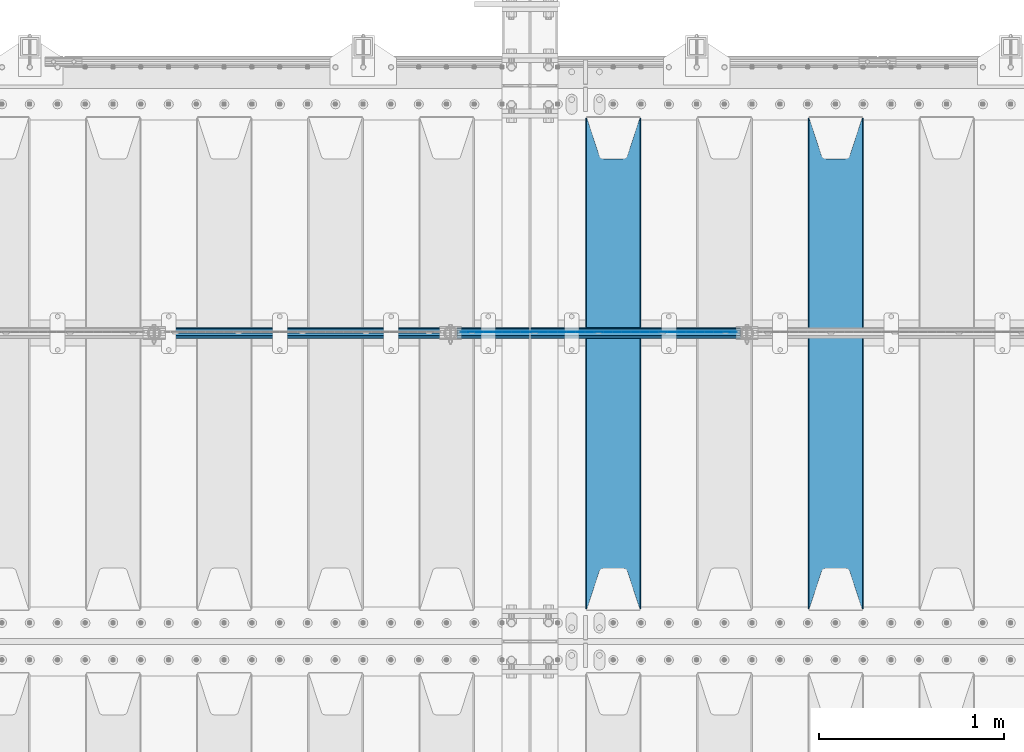
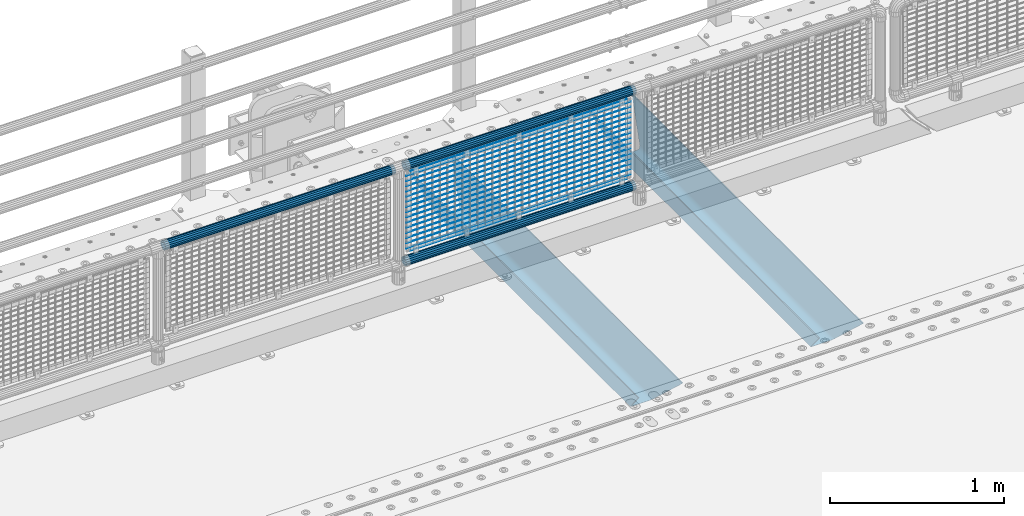
# One storey, part 106 of 208: 22 beams.
"""IFC2X3 building model written with IfcOpenShell, lengths in millimetres."""

from ifc_helpers import new_model, si_unit, frame, origin_with_axes, place, context, subcontext, project, spatial, faceted_brep, material, type_object, element, save


model = new_model("IFC2X3")

# Units and contexts
model_context = context("Model", 3, precision=1e-05, world=origin_with_axes())
body_context = subcontext(model_context, "Body", "Model", "MODEL_VIEW")
ifc_project = project(units=[si_unit("LENGTHUNIT", "METRE", prefix="MILLI"), si_unit("AREAUNIT", "SQUARE_METRE"), si_unit("VOLUMEUNIT", "CUBIC_METRE"), si_unit("MASSUNIT", "GRAM", prefix="KILO"), si_unit("TIMEUNIT", "SECOND"), si_unit("PLANEANGLEUNIT", "RADIAN"), si_unit("SOLIDANGLEUNIT", "STERADIAN"), si_unit("THERMODYNAMICTEMPERATUREUNIT", "DEGREE_CELSIUS"), si_unit("LUMINOUSINTENSITYUNIT", "LUMEN")], contexts=[model_context])

# Site, building, storey
site_placement = place(None, origin_with_axes())
site = spatial("IfcSite", under=ifc_project, at=site_placement, CompositionType="ELEMENT")
building_placement = place(site_placement, origin_with_axes())
building = spatial("IfcBuilding", under=site, at=building_placement, Name="Standard", CompositionType="ELEMENT")
storey_placement = place(building_placement, origin_with_axes())
storey = spatial("IfcBuildingStorey", under=building, at=storey_placement, Name="Undefined", CompositionType="ELEMENT", Elevation=0.0)

# Beams
ifc_material_1 = material(Name="STEEL/S355N")
beam_type_1 = type_object("IfcBeamType", PredefinedType="NOTDEFINED")
beam_1_placement = place(storey_placement, frame((-28550.0, 3175.0, -115.0), z_axis=(0.0, 0.0, 1.0), x_axis=(0.0, 1.0, 0.0)))
element("IfcBeam", 1, at=beam_1_placement, inside=storey, type_object=beam_type_1, material=ifc_material_1, context=body_context, shape_type="Brep", body=[
    faceted_brep([(0.0, 150.0, 115.0), (0.0, 143.689999999999, 115.0), (2650.00000000297, 143.689999999999, 115.0), (2650.00000000297, 150.0, 115.0), (2650.00000000297, 142.059565218402, 110.0000000031), (2650.00000000297, 148.369565218403, 110.0000000031), (2441.90079219208, -80.1103600731112, -98.0992078077845), (2437.7588105432, -77.5672621345584, -102.241189456673), (2434.06523489746, -74.4080125315522, -105.934765102404), (2430.91086095089, -70.710272125576, -109.089139048974), (2428.37322971128, -66.5649389910068, -111.626770288588), (2426.51472138055, -62.0739139532889, -113.485278619323), (2425.38102192091, -57.3475956567672, -114.618978078955), (2424.99999999987, -52.5021667386536, -115.0), (2424.99999999987, 52.5021667386536, -115.0), (2425.38102192091, 57.3475956567672, -114.618978078955), (2426.51472138055, 62.0739139532889, -113.485278619323), (2428.37322971128, 66.5649389910068, -111.626770288588), (2430.91086095089, 70.710272125576, -109.089139048974), (2434.06523489746, 74.4080125315522, -105.934765102404), (2437.7588105432, 77.5672621345584, -102.241189456673), (2441.90079219208, 80.1103600731112, -98.0992078077846), (2446.38936140511, 81.9747917625791, -93.6106385947584), (2448.24948500409, 76.2713538057251, -91.7505149957729), (2444.62967112262, 74.76777986261, -95.3703288772456), (2441.28936334126, 72.7168944282894, -98.710636658607), (2438.31067330438, 70.1691124903846, -101.689326695487), (2435.76682334747, 67.1870637758839, -104.233176652398), (2433.72034654133, 63.8440531834895, -106.279653458539), (2432.22154950041, 60.222258798236, -107.778450499454), (2431.30727574265, 56.4107117849089, -108.692724257221), (2430.99999999987, 52.5031078186876, -109.0), (2430.99999999987, -52.5031078186876, -109.0), (2431.30727574265, -56.4107117849089, -108.692724257221), (2432.22154950041, -60.222258798236, -107.778450499454), (2433.72034654133, -63.8440531834895, -106.279653458539), (2435.76682334747, -67.1870637758839, -104.233176652398), (2438.31067330438, -70.1691124903846, -101.689326695487), (2441.28936334126, -72.7168944282894, -98.7106366586071), (2444.62967112262, -74.76777986261, -95.3703288772457), (2448.24948500409, -76.2713538057251, -91.7505149957729), (2650.00000000297, -142.059565218402, 110.0000000031), (2650.00000000297, -148.369565218403, 110.0000000031), (2446.38936140511, -81.9747917625791, -93.6106385947584), (2650.00000000297, -143.689999999999, 115.0), (2650.00000000297, -150.0, 115.0), (0.0, -143.689999999999, 115.0), (0.0, -150.0, 115.0), (0.0, -148.369565218261, 110.000000002663), (203.610638597421, -81.9747917625791, -93.6106385947584), (208.099207810448, -80.1103600731112, -98.0992078077845), (212.241189459336, -77.5672621345584, -102.241189456673), (215.934765105067, -74.4080125315522, -105.934765102404), (219.089139051637, -70.710272125576, -109.089139048974), (221.626770291251, -66.5649389910068, -111.626770288588), (223.485278621986, -62.0739139532889, -113.485278619323), (224.618978081618, -57.3475956567672, -114.618978078955), (225.000000002663, -52.5021667386536, -115.0), (225.000000002663, 52.5021667386536, -115.0), (224.618978081618, 57.3475956567672, -114.618978078955), (223.485278621986, 62.0739139532889, -113.485278619323), (221.626770291251, 66.5649389910068, -111.626770288588), (219.089139051637, 70.710272125576, -109.089139048974), (215.934765105067, 74.4080125315522, -105.934765102404), (212.241189459336, 77.5672621345584, -102.241189456673), (208.099207810448, 80.1103600731112, -98.0992078077846), (203.610638597421, 81.9747917625791, -93.6106385947584), (0.0, 148.369565218261, 110.000000002663), (0.0, 142.05956521826, 110.000000002663), (201.750514998436, 76.2713538057251, -91.7505149957729), (205.370328879908, 74.76777986261, -95.3703288772456), (208.71063666127, 72.7168944282894, -98.710636658607), (211.68932669815, 70.1691124903846, -101.689326695487), (214.233176655061, 67.1870637758839, -104.233176652398), (216.279653461202, 63.8440531834895, -106.279653458539), (217.778450502116, 60.222258798236, -107.778450499454), (218.692724259884, 56.4107117849089, -108.692724257221), (219.000000002663, 52.5031078186876, -109.0), (219.000000002663, -52.5031078186876, -109.0), (218.692724259884, -56.4107117849089, -108.692724257221), (217.778450502116, -60.222258798236, -107.778450499454), (216.279653461202, -63.8440531834895, -106.279653458539), (214.233176655061, -67.1870637758839, -104.233176652398), (211.68932669815, -70.1691124903846, -101.689326695487), (208.71063666127, -72.7168944282894, -98.7106366586071), (205.370328879908, -74.76777986261, -95.3703288772457), (201.750514998436, -76.2713538057251, -91.7505149957729), (0.0, -142.05956521826, 110.000000002663)], [[[0, 1, 2, 3]], [[3, 2, 4, 5]], [[6, 7, 8, 9, 10, 11, 12, 13, 14, 15, 16, 17, 18, 19, 20, 21, 22, 5, 4, 23, 24, 25, 26, 27, 28, 29, 30, 31, 32, 33, 34, 35, 36, 37, 38, 39, 40, 41, 42, 43]], [[44, 45, 42, 41]], [[46, 47, 45, 44]], [[43, 42, 45, 47, 48, 49]], [[6, 43, 49, 50]], [[7, 6, 50, 51]], [[8, 7, 51, 52]], [[9, 8, 52, 53]], [[10, 9, 53, 54]], [[11, 10, 54, 55]], [[12, 11, 55, 56]], [[13, 12, 56, 57]], [[14, 13, 57, 58]], [[15, 14, 58, 59]], [[16, 15, 59, 60]], [[17, 16, 60, 61]], [[18, 17, 61, 62]], [[19, 18, 62, 63]], [[20, 19, 63, 64]], [[21, 20, 64, 65]], [[22, 21, 65, 66]], [[0, 3, 5, 22, 66, 67]], [[1, 0, 67, 68]], [[23, 4, 2, 1, 68, 69]], [[24, 23, 69, 70]], [[25, 24, 70, 71]], [[26, 25, 71, 72]], [[27, 26, 72, 73]], [[28, 27, 73, 74]], [[29, 28, 74, 75]], [[30, 29, 75, 76]], [[31, 30, 76, 77]], [[32, 31, 77, 78]], [[33, 32, 78, 79]], [[34, 33, 79, 80]], [[35, 34, 80, 81]], [[36, 35, 81, 82]], [[37, 36, 82, 83]], [[38, 37, 83, 84]], [[39, 38, 84, 85]], [[40, 39, 85, 86]], [[46, 44, 41, 40, 86, 87]], [[47, 46, 87, 48]], [[86, 85, 84, 83, 82, 81, 80, 79, 78, 77, 76, 75, 74, 73, 72, 71, 70, 69, 68, 67, 66, 65, 64, 63, 62, 61, 60, 59, 58, 57, 56, 55, 54, 53, 52, 51, 50, 49, 48, 87]]]),
])
beam_2_placement = place(storey_placement, frame((-29750.0, 3175.0, -115.0), z_axis=(0.0, 0.0, 1.0), x_axis=(0.0, 1.0, 0.0)))
element("IfcBeam", 2, at=beam_2_placement, inside=storey, type_object=beam_type_1, material=ifc_material_1, context=body_context, shape_type="Brep", body=[
    faceted_brep([(0.0, 150.0, 115.0), (0.0, 143.689999999999, 115.0), (2650.00000000297, 143.689999999999, 115.0), (2650.00000000297, 150.0, 115.0), (2650.00000000297, 142.059565218402, 110.0000000031), (2650.00000000297, 148.369565218403, 110.0000000031), (2441.90079219208, -80.1103600731112, -98.0992078077845), (2437.7588105432, -77.5672621345584, -102.241189456673), (2434.06523489746, -74.4080125315522, -105.934765102404), (2430.91086095089, -70.710272125576, -109.089139048974), (2428.37322971128, -66.5649389910068, -111.626770288588), (2426.51472138055, -62.0739139532889, -113.485278619323), (2425.38102192091, -57.3475956567672, -114.618978078955), (2424.99999999987, -52.5021667386536, -115.0), (2424.99999999987, 52.5021667386536, -115.0), (2425.38102192091, 57.3475956567672, -114.618978078955), (2426.51472138055, 62.0739139532889, -113.485278619323), (2428.37322971128, 66.5649389910068, -111.626770288588), (2430.91086095089, 70.710272125576, -109.089139048974), (2434.06523489746, 74.4080125315522, -105.934765102404), (2437.7588105432, 77.5672621345584, -102.241189456673), (2441.90079219208, 80.1103600731112, -98.0992078077846), (2446.38936140511, 81.9747917625791, -93.6106385947584), (2448.24948500409, 76.2713538057251, -91.7505149957729), (2444.62967112262, 74.76777986261, -95.3703288772456), (2441.28936334126, 72.7168944282894, -98.710636658607), (2438.31067330438, 70.1691124903846, -101.689326695487), (2435.76682334747, 67.1870637758839, -104.233176652398), (2433.72034654133, 63.8440531834895, -106.279653458539), (2432.22154950041, 60.222258798236, -107.778450499454), (2431.30727574265, 56.4107117849089, -108.692724257221), (2430.99999999987, 52.5031078186876, -109.0), (2430.99999999987, -52.5031078186876, -109.0), (2431.30727574265, -56.4107117849089, -108.692724257221), (2432.22154950041, -60.222258798236, -107.778450499454), (2433.72034654133, -63.8440531834895, -106.279653458539), (2435.76682334747, -67.1870637758839, -104.233176652398), (2438.31067330438, -70.1691124903846, -101.689326695487), (2441.28936334126, -72.7168944282894, -98.7106366586071), (2444.62967112262, -74.76777986261, -95.3703288772457), (2448.24948500409, -76.2713538057251, -91.7505149957729), (2650.00000000297, -142.059565218402, 110.0000000031), (2650.00000000297, -148.369565218403, 110.0000000031), (2446.38936140511, -81.9747917625791, -93.6106385947584), (2650.00000000297, -143.689999999999, 115.0), (2650.00000000297, -150.0, 115.0), (0.0, -143.689999999999, 115.0), (0.0, -150.0, 115.0), (0.0, -148.369565218261, 110.000000002663), (203.610638597421, -81.9747917625791, -93.6106385947584), (208.099207810448, -80.1103600731112, -98.0992078077845), (212.241189459336, -77.5672621345584, -102.241189456673), (215.934765105067, -74.4080125315522, -105.934765102404), (219.089139051637, -70.710272125576, -109.089139048974), (221.626770291251, -66.5649389910068, -111.626770288588), (223.485278621986, -62.0739139532889, -113.485278619323), (224.618978081618, -57.3475956567672, -114.618978078955), (225.000000002663, -52.5021667386536, -115.0), (225.000000002663, 52.5021667386536, -115.0), (224.618978081618, 57.3475956567672, -114.618978078955), (223.485278621986, 62.0739139532889, -113.485278619323), (221.626770291251, 66.5649389910068, -111.626770288588), (219.089139051637, 70.710272125576, -109.089139048974), (215.934765105067, 74.4080125315522, -105.934765102404), (212.241189459336, 77.5672621345584, -102.241189456673), (208.099207810448, 80.1103600731112, -98.0992078077846), (203.610638597421, 81.9747917625791, -93.6106385947584), (0.0, 148.369565218261, 110.000000002663), (0.0, 142.05956521826, 110.000000002663), (201.750514998436, 76.2713538057251, -91.7505149957729), (205.370328879908, 74.76777986261, -95.3703288772456), (208.71063666127, 72.7168944282894, -98.710636658607), (211.68932669815, 70.1691124903846, -101.689326695487), (214.233176655061, 67.1870637758839, -104.233176652398), (216.279653461202, 63.8440531834895, -106.279653458539), (217.778450502116, 60.222258798236, -107.778450499454), (218.692724259884, 56.4107117849089, -108.692724257221), (219.000000002663, 52.5031078186876, -109.0), (219.000000002663, -52.5031078186876, -109.0), (218.692724259884, -56.4107117849089, -108.692724257221), (217.778450502116, -60.222258798236, -107.778450499454), (216.279653461202, -63.8440531834895, -106.279653458539), (214.233176655061, -67.1870637758839, -104.233176652398), (211.68932669815, -70.1691124903846, -101.689326695487), (208.71063666127, -72.7168944282894, -98.7106366586071), (205.370328879908, -74.76777986261, -95.3703288772457), (201.750514998436, -76.2713538057251, -91.7505149957729), (0.0, -142.05956521826, 110.000000002663)], [[[0, 1, 2, 3]], [[3, 2, 4, 5]], [[6, 7, 8, 9, 10, 11, 12, 13, 14, 15, 16, 17, 18, 19, 20, 21, 22, 5, 4, 23, 24, 25, 26, 27, 28, 29, 30, 31, 32, 33, 34, 35, 36, 37, 38, 39, 40, 41, 42, 43]], [[44, 45, 42, 41]], [[46, 47, 45, 44]], [[43, 42, 45, 47, 48, 49]], [[6, 43, 49, 50]], [[7, 6, 50, 51]], [[8, 7, 51, 52]], [[9, 8, 52, 53]], [[10, 9, 53, 54]], [[11, 10, 54, 55]], [[12, 11, 55, 56]], [[13, 12, 56, 57]], [[14, 13, 57, 58]], [[15, 14, 58, 59]], [[16, 15, 59, 60]], [[17, 16, 60, 61]], [[18, 17, 61, 62]], [[19, 18, 62, 63]], [[20, 19, 63, 64]], [[21, 20, 64, 65]], [[22, 21, 65, 66]], [[0, 3, 5, 22, 66, 67]], [[1, 0, 67, 68]], [[23, 4, 2, 1, 68, 69]], [[24, 23, 69, 70]], [[25, 24, 70, 71]], [[26, 25, 71, 72]], [[27, 26, 72, 73]], [[28, 27, 73, 74]], [[29, 28, 74, 75]], [[30, 29, 75, 76]], [[31, 30, 76, 77]], [[32, 31, 77, 78]], [[33, 32, 78, 79]], [[34, 33, 79, 80]], [[35, 34, 80, 81]], [[36, 35, 81, 82]], [[37, 36, 82, 83]], [[38, 37, 83, 84]], [[39, 38, 84, 85]], [[40, 39, 85, 86]], [[46, 44, 41, 40, 86, 87]], [[47, 46, 87, 48]], [[86, 85, 84, 83, 82, 81, 80, 79, 78, 77, 76, 75, 74, 73, 72, 71, 70, 69, 68, 67, 66, 65, 64, 63, 62, 61, 60, 59, 58, 57, 56, 55, 54, 53, 52, 51, 50, 49, 48, 87]]]),
])
ifc_material_2 = material(Name="Misc_Undefined")
beam_type_2 = type_object("IfcBeamType", Name="D3", PredefinedType="NOTDEFINED")
for number, where, z_axis, x_axis in (
    (3, (-30574.0, 4670.50000000001, 851.597000000005), (0.0, 0.0, 1.0), (1.0, 0.0, 0.0)),
    (4, (-30574.0, 4670.50000000001, 669.452000000005), (0.0, 0.0, 1.0), (1.0, 0.0, 0.0)),
    (5, (-30574.0, 4670.50000000001, 523.736000000005), (0.0, 0.0, 1.0), (1.0, 0.0, 0.0)),
    (6, (-30574.0, 4670.50000000001, 487.307000000005), (0.0, 0.0, 1.0), (1.0, 0.0, 0.0)),
    (7, (-30574.0, 4670.50000000001, 705.881000000005), (0.0, 0.0, 1.0), (1.0, 0.0, 0.0)),
    (8, (-30574.0, 4670.50000000001, 596.594000000005), (0.0, 0.0, 1.0), (1.0, 0.0, 0.0)),
    (9, (-30574.0, 4670.50000000001, 450.878000000005), (0.0, 0.0, 1.0), (1.0, 0.0, 0.0)),
    (10, (-30574.0, 4670.50000000001, 815.168000000005), (0.0, 0.0, 1.0), (1.0, 0.0, 0.0)),
    (11, (-30574.0, 4670.50000000001, 888.026000000005), (0.0, 0.0, 1.0), (1.0, 0.0, 0.0)),
    (12, (-30574.0, 4670.50000000001, 778.739000000005), (0.0, 0.0, 1.0), (1.0, 0.0, 0.0)),
    (13, (-30574.0, 4670.50000000001, 742.310000000005), (0.0, 0.0, 1.0), (1.0, 0.0, 0.0)),
    (14, (-30574.0, 4670.50000000001, 633.023000000005), (0.0, 0.0, 1.0), (1.0, 0.0, 0.0)),
    (15, (-30574.0, 4670.50000000001, 560.165000000005), (0.0, 0.0, 1.0), (1.0, 0.0, 0.0)),
    (16, (-30574.0, 4670.50000000001, 414.449000000005), (0.0, 0.0, 1.0), (1.0, 0.0, 0.0)),
):
    element("IfcBeam", number, at=place(storey_placement, frame(where, z_axis=z_axis, x_axis=x_axis)), inside=storey, type_object=beam_type_2, material=ifc_material_2, ObjectType="D3", context=body_context, shape_type="Brep", body=[
        faceted_brep([(0.0, -1.49999999999909, 3.63797880709171e-12), (-7.27595761418343e-12, -0.749999999999091, -1.29903810567669), (1490.0, -0.75, -1.29903810567669), (1490.0, -1.5, 0.0), (-3.63797880709171e-12, 0.750000000000909, -1.29903810567669), (1490.0, 0.75, -1.29903810567669), (0.0, 1.50000000000182, 3.63797880709171e-12), (1490.0, 1.5, 0.0), (-3.63797880709171e-12, 0.750000000000909, 1.29903810567669), (1490.0, 0.75, 1.29903810567669), (-7.27595761418343e-12, -0.749999999999091, 1.29903810567669), (1490.0, -0.75, 1.29903810567669)], [[[0, 1, 2, 3]], [[1, 4, 5, 2]], [[4, 6, 7, 5]], [[6, 8, 9, 7]], [[8, 10, 11, 9]], [[10, 0, 3, 11]], [[5, 7, 9, 11, 3, 2]], [[10, 8, 6, 4, 1, 0]]]),
    ])
beam_3_placement = place(storey_placement, frame((-30549.0, 4670.50000000001, 353.020000000005), z_axis=(0.0, 0.0, 1.0), x_axis=(1.0, 0.0, 0.0)))
element("IfcBeam", 17, at=beam_3_placement, inside=storey, type_object=beam_type_2, material=ifc_material_2, ObjectType="D3", context=body_context, shape_type="Brep", body=[
    faceted_brep([(0.0, -1.49999999999909, 3.63797880709171e-12), (-7.27595761418343e-12, -0.749999999999091, -1.29903810567669), (1440.0, -0.75, -1.29903810567669), (1440.0, -1.5, 0.0), (-3.63797880709171e-12, 0.750000000000909, -1.29903810567669), (1440.0, 0.75, -1.29903810567663), (0.0, 1.50000000000182, 3.63797880709171e-12), (1440.0, 1.5, 0.0), (-3.63797880709171e-12, 0.750000000000909, 1.29903810567669), (1440.0, 0.75, 1.29903810567669), (-7.27595761418343e-12, -0.749999999999091, 1.29903810567669), (1440.0, -0.75, 1.29903810567669)], [[[0, 1, 2, 3]], [[1, 4, 5, 2]], [[4, 6, 7, 5]], [[6, 8, 9, 7]], [[8, 10, 11, 9]], [[10, 0, 3, 11]], [[5, 7, 9, 11, 3, 2]], [[10, 8, 6, 4, 1, 0]]]),
])
beam_4_placement = place(storey_placement, frame((-30574.0, 4670.50000000001, 378.020000000005), z_axis=(0.0, 0.0, 1.0), x_axis=(1.0, 0.0, 0.0)))
element("IfcBeam", 18, at=beam_4_placement, inside=storey, type_object=beam_type_2, material=ifc_material_2, ObjectType="D3", context=body_context, shape_type="Brep", body=[
    faceted_brep([(0.0, -1.49999999999909, 3.63797880709171e-12), (-7.27595761418343e-12, -0.749999999999091, -1.29903810567669), (1490.0, -0.75, -1.29903810567669), (1490.0, -1.5, 0.0), (-3.63797880709171e-12, 0.750000000000909, -1.29903810567669), (1490.0, 0.75, -1.29903810567669), (0.0, 1.50000000000182, 3.63797880709171e-12), (1490.0, 1.5, 0.0), (-3.63797880709171e-12, 0.750000000000909, 1.29903810567669), (1490.0, 0.75, 1.29903810567669), (-7.27595761418343e-12, -0.749999999999091, 1.29903810567669), (1490.0, -0.75, 1.29903810567669)], [[[0, 1, 2, 3]], [[1, 4, 5, 2]], [[4, 6, 7, 5]], [[6, 8, 9, 7]], [[8, 10, 11, 9]], [[10, 0, 3, 11]], [[5, 7, 9, 11, 3, 2]], [[10, 8, 6, 4, 1, 0]]]),
])
beam_5_placement = place(storey_placement, frame((-30549.0, 4670.50000000001, 913.020000000005), z_axis=(0.0, 0.0, 1.0), x_axis=(1.0, 0.0, 0.0)))
element("IfcBeam", 19, at=beam_5_placement, inside=storey, type_object=beam_type_2, material=ifc_material_2, ObjectType="D3", context=body_context, shape_type="Brep", body=[
    faceted_brep([(0.0, -1.49999999999909, 3.63797880709171e-12), (-7.27595761418343e-12, -0.749999999999091, -1.29903810567669), (1440.0, -0.75, -1.29903810567669), (1440.0, -1.5, 0.0), (-3.63797880709171e-12, 0.750000000000909, -1.29903810567669), (1440.0, 0.75, -1.29903810567663), (0.0, 1.50000000000182, 3.63797880709171e-12), (1440.0, 1.5, 0.0), (-3.63797880709171e-12, 0.750000000000909, 1.29903810567669), (1440.0, 0.75, 1.29903810567669), (-7.27595761418343e-12, -0.749999999999091, 1.29903810567669), (1440.0, -0.75, 1.29903810567669)], [[[0, 1, 2, 3]], [[1, 4, 5, 2]], [[4, 6, 7, 5]], [[6, 8, 9, 7]], [[8, 10, 11, 9]], [[10, 0, 3, 11]], [[5, 7, 9, 11, 3, 2]], [[10, 8, 6, 4, 1, 0]]]),
])
ifc_material_3 = material()
beam_type_3 = type_object("IfcBeamType", PredefinedType="NOTDEFINED")
beam_6_placement = place(storey_placement, frame((-30594.15, 4664.50000000001, 298.170000000006), z_axis=(0.0, 0.0, 1.0), x_axis=(1.0, 0.0, 0.0)))
element("IfcBeam", 20, at=beam_6_placement, inside=storey, type_object=beam_type_3, material=ifc_material_3, context=body_context, shape_type="Brep", body=[
    faceted_brep([(0.0, -25.3500000000004, 0.0), (0.0, -23.4203461491616, 9.70102501045403), (1530.0, -23.4203461491616, 9.70102501045506), (1530.0, -25.3500000000004, 0.0), (0.0, -17.9251569030794, 17.9251569030785), (1530.0, -17.9251569030794, 17.925156903079), (0.0, -9.70102501045494, 23.4203461491597), (1530.0, -9.70102501045494, 23.4203461491611), (0.0, 0.0, 25.3499999999985), (1530.0, 0.0, 25.35), (0.0, 9.70102501045494, 23.4203461491597), (1530.0, 9.70102501045494, 23.4203461491611), (0.0, 17.9251569030794, 17.9251569030785), (1530.0, 17.9251569030794, 17.925156903079), (0.0, 23.4203461491616, 9.70102501045403), (1530.0, 23.4203461491616, 9.701025010455), (0.0, 25.3500000000004, 0.0), (1530.0, 25.3500000000004, 0.0), (0.0, 23.4203461491616, -9.70102501045403), (1530.0, 23.4203461491616, -9.70102501045506), (0.0, 17.9251569030794, -17.9251569030785), (1530.0, 17.9251569030794, -17.925156903079), (0.0, 9.70102501045494, -23.4203461491597), (1530.0, 9.70102501045494, -23.4203461491611), (0.0, 0.0, -25.3499999999985), (1530.0, 0.0, -25.35), (0.0, -9.70102501045494, -23.4203461491597), (1530.0, -9.70102501045494, -23.4203461491611), (0.0, -17.9251569030794, -17.9251569030785), (1530.0, -17.9251569030794, -17.925156903079), (0.0, -23.4203461491616, -9.70102501045403), (1530.0, -23.4203461491616, -9.701025010455), (0.0, -30.1499999999996, 0.0), (0.0, -27.8549679052148, -11.5379054858058), (1530.0, -27.8549679052148, -11.5379054858075), (1530.0, -30.1499999999996, 0.0), (0.0, -21.3192694527743, -21.3192694527752), (1530.0, -21.3192694527743, -21.3192694527744), (0.0, -11.5379054858076, -27.8549679052157), (1530.0, -11.5379054858076, -27.8549679052153), (0.0, 0.0, -30.1500000000015), (1530.0, 0.0, -30.15), (0.0, 11.5379054858076, -27.8549679052157), (1530.0, 11.5379054858076, -27.8549679052153), (0.0, 21.3192694527743, -21.3192694527752), (1530.0, 21.3192694527743, -21.3192694527744), (0.0, 27.8549679052157, -11.5379054858058), (1530.0, 27.8549679052157, -11.5379054858075), (0.0, 30.1499999999996, 0.0), (1530.0, 30.1499999999996, 0.0), (0.0, 27.8549679052157, 11.5379054858058), (1530.0, 27.8549679052157, 11.5379054858075), (0.0, 21.3192694527743, 21.3192694527752), (1530.0, 21.3192694527743, 21.3192694527744), (0.0, 11.5379054858076, 27.8549679052157), (1530.0, 11.5379054858076, 27.8549679052153), (0.0, 0.0, 30.1500000000015), (1530.0, 0.0, 30.15), (0.0, -11.5379054858076, 27.8549679052157), (1530.0, -11.5379054858076, 27.8549679052153), (0.0, -21.3192694527743, 21.3192694527752), (1530.0, -21.3192694527743, 21.3192694527744), (0.0, -27.8549679052157, 11.5379054858058), (1530.0, -27.8549679052157, 11.5379054858075)], [[[0, 1, 2, 3]], [[1, 4, 5, 2]], [[4, 6, 7, 5]], [[6, 8, 9, 7]], [[8, 10, 11, 9]], [[10, 12, 13, 11]], [[12, 14, 15, 13]], [[14, 16, 17, 15]], [[16, 18, 19, 17]], [[18, 20, 21, 19]], [[20, 22, 23, 21]], [[22, 24, 25, 23]], [[24, 26, 27, 25]], [[26, 28, 29, 27]], [[28, 30, 31, 29]], [[30, 0, 3, 31]], [[32, 33, 34, 35]], [[33, 36, 37, 34]], [[36, 38, 39, 37]], [[38, 40, 41, 39]], [[40, 42, 43, 41]], [[42, 44, 45, 43]], [[44, 46, 47, 45]], [[46, 48, 49, 47]], [[48, 50, 51, 49]], [[50, 52, 53, 51]], [[52, 54, 55, 53]], [[54, 56, 57, 55]], [[56, 58, 59, 57]], [[58, 60, 61, 59]], [[60, 62, 63, 61]], [[62, 32, 35, 63]], [[37, 39, 41, 43, 45, 47, 49, 51, 53, 55, 57, 59, 61, 63, 35, 34], [5, 7, 9, 11, 13, 15, 17, 19, 21, 23, 25, 27, 29, 31, 3, 2]], [[62, 60, 58, 56, 54, 52, 50, 48, 46, 44, 42, 40, 38, 36, 33, 32], [30, 28, 26, 24, 22, 20, 18, 16, 14, 12, 10, 8, 6, 4, 1, 0]]]),
])
beam_7_placement = place(storey_placement, frame((-30594.15, 4664.50000000001, 969.850000000005), z_axis=(0.0, 0.0, 1.0), x_axis=(1.0, 0.0, 0.0)))
element("IfcBeam", 21, at=beam_7_placement, inside=storey, type_object=beam_type_3, material=ifc_material_3, context=body_context, shape_type="Brep", body=[
    faceted_brep([(0.0, -25.3500000000004, 0.0), (0.0, -23.4203461491616, 9.70102501045403), (1530.0, -23.4203461491616, 9.70102501045506), (1530.0, -25.3500000000004, 0.0), (0.0, -17.9251569030794, 17.9251569030785), (1530.0, -17.9251569030794, 17.925156903079), (0.0, -9.70102501045494, 23.4203461491597), (1530.0, -9.70102501045494, 23.4203461491611), (0.0, 0.0, 25.3499999999985), (1530.0, 0.0, 25.35), (0.0, 9.70102501045494, 23.4203461491597), (1530.0, 9.70102501045494, 23.4203461491611), (0.0, 17.9251569030794, 17.9251569030785), (1530.0, 17.9251569030794, 17.925156903079), (0.0, 23.4203461491616, 9.70102501045403), (1530.0, 23.4203461491616, 9.701025010455), (0.0, 25.3500000000004, 0.0), (1530.0, 25.3500000000004, 0.0), (0.0, 23.4203461491616, -9.70102501045403), (1530.0, 23.4203461491616, -9.70102501045506), (0.0, 17.9251569030794, -17.9251569030785), (1530.0, 17.9251569030794, -17.925156903079), (0.0, 9.70102501045494, -23.4203461491597), (1530.0, 9.70102501045494, -23.4203461491611), (0.0, 0.0, -25.3499999999985), (1530.0, 0.0, -25.35), (0.0, -9.70102501045494, -23.4203461491597), (1530.0, -9.70102501045494, -23.4203461491611), (0.0, -17.9251569030794, -17.9251569030785), (1530.0, -17.9251569030794, -17.925156903079), (0.0, -23.4203461491616, -9.70102501045403), (1530.0, -23.4203461491616, -9.701025010455), (0.0, -30.1499999999996, 0.0), (0.0, -27.8549679052148, -11.5379054858058), (1530.0, -27.8549679052148, -11.5379054858075), (1530.0, -30.1499999999996, 0.0), (0.0, -21.3192694527743, -21.3192694527752), (1530.0, -21.3192694527743, -21.3192694527744), (0.0, -11.5379054858076, -27.8549679052157), (1530.0, -11.5379054858076, -27.8549679052153), (0.0, 0.0, -30.1500000000015), (1530.0, 0.0, -30.15), (0.0, 11.5379054858076, -27.8549679052157), (1530.0, 11.5379054858076, -27.8549679052153), (0.0, 21.3192694527743, -21.3192694527752), (1530.0, 21.3192694527743, -21.3192694527744), (0.0, 27.8549679052157, -11.5379054858058), (1530.0, 27.8549679052157, -11.5379054858075), (0.0, 30.1499999999996, 0.0), (1530.0, 30.1499999999996, 0.0), (0.0, 27.8549679052157, 11.5379054858058), (1530.0, 27.8549679052157, 11.5379054858075), (0.0, 21.3192694527743, 21.3192694527752), (1530.0, 21.3192694527743, 21.3192694527744), (0.0, 11.5379054858076, 27.8549679052157), (1530.0, 11.5379054858076, 27.8549679052153), (0.0, 0.0, 30.1500000000015), (1530.0, 0.0, 30.15), (0.0, -11.5379054858076, 27.8549679052157), (1530.0, -11.5379054858076, 27.8549679052153), (0.0, -21.3192694527743, 21.3192694527752), (1530.0, -21.3192694527743, 21.3192694527744), (0.0, -27.8549679052157, 11.5379054858058), (1530.0, -27.8549679052157, 11.5379054858075)], [[[0, 1, 2, 3]], [[1, 4, 5, 2]], [[4, 6, 7, 5]], [[6, 8, 9, 7]], [[8, 10, 11, 9]], [[10, 12, 13, 11]], [[12, 14, 15, 13]], [[14, 16, 17, 15]], [[16, 18, 19, 17]], [[18, 20, 21, 19]], [[20, 22, 23, 21]], [[22, 24, 25, 23]], [[24, 26, 27, 25]], [[26, 28, 29, 27]], [[28, 30, 31, 29]], [[30, 0, 3, 31]], [[32, 33, 34, 35]], [[33, 36, 37, 34]], [[36, 38, 39, 37]], [[38, 40, 41, 39]], [[40, 42, 43, 41]], [[42, 44, 45, 43]], [[44, 46, 47, 45]], [[46, 48, 49, 47]], [[48, 50, 51, 49]], [[50, 52, 53, 51]], [[52, 54, 55, 53]], [[54, 56, 57, 55]], [[56, 58, 59, 57]], [[58, 60, 61, 59]], [[60, 62, 63, 61]], [[62, 32, 35, 63]], [[37, 39, 41, 43, 45, 47, 49, 51, 53, 55, 57, 59, 61, 63, 35, 34], [5, 7, 9, 11, 13, 15, 17, 19, 21, 23, 25, 27, 29, 31, 3, 2]], [[62, 60, 58, 56, 54, 52, 50, 48, 46, 44, 42, 40, 38, 36, 33, 32], [30, 28, 26, 24, 22, 20, 18, 16, 14, 12, 10, 8, 6, 4, 1, 0]]]),
])
beam_8_placement = place(storey_placement, frame((-32194.15, 4664.5, 969.850000000004), z_axis=(0.0, 0.0, 1.0), x_axis=(1.0, 0.0, 0.0)))
element("IfcBeam", 22, at=beam_8_placement, inside=storey, type_object=beam_type_3, material=ifc_material_3, context=body_context, shape_type="Brep", body=[
    faceted_brep([(0.0, -25.3500000000004, 0.0), (0.0, -23.4203461491616, 9.70102501045403), (1530.0, -23.4203461491616, 9.70102501045506), (1530.0, -25.3500000000004, 0.0), (0.0, -17.9251569030794, 17.9251569030785), (1530.0, -17.9251569030794, 17.925156903079), (0.0, -9.70102501045494, 23.4203461491597), (1530.0, -9.70102501045494, 23.4203461491611), (0.0, 0.0, 25.3499999999985), (1530.0, 0.0, 25.35), (0.0, 9.70102501045494, 23.4203461491597), (1530.0, 9.70102501045494, 23.4203461491611), (0.0, 17.9251569030794, 17.9251569030785), (1530.0, 17.9251569030794, 17.925156903079), (0.0, 23.4203461491616, 9.70102501045403), (1530.0, 23.4203461491616, 9.701025010455), (0.0, 25.3500000000004, 0.0), (1530.0, 25.3500000000004, 0.0), (0.0, 23.4203461491616, -9.70102501045403), (1530.0, 23.4203461491616, -9.70102501045506), (0.0, 17.9251569030794, -17.9251569030785), (1530.0, 17.9251569030794, -17.925156903079), (0.0, 9.70102501045494, -23.4203461491597), (1530.0, 9.70102501045494, -23.4203461491611), (0.0, 0.0, -25.3499999999985), (1530.0, 0.0, -25.35), (0.0, -9.70102501045494, -23.4203461491597), (1530.0, -9.70102501045494, -23.4203461491611), (0.0, -17.9251569030794, -17.9251569030785), (1530.0, -17.9251569030794, -17.925156903079), (0.0, -23.4203461491616, -9.70102501045403), (1530.0, -23.4203461491616, -9.701025010455), (0.0, -30.1499999999996, 0.0), (0.0, -27.8549679052148, -11.5379054858058), (1530.0, -27.8549679052148, -11.5379054858075), (1530.0, -30.1499999999996, 0.0), (0.0, -21.3192694527743, -21.3192694527752), (1530.0, -21.3192694527743, -21.3192694527744), (0.0, -11.5379054858076, -27.8549679052157), (1530.0, -11.5379054858076, -27.8549679052153), (0.0, 0.0, -30.1500000000015), (1530.0, 0.0, -30.15), (0.0, 11.5379054858076, -27.8549679052157), (1530.0, 11.5379054858076, -27.8549679052153), (0.0, 21.3192694527743, -21.3192694527752), (1530.0, 21.3192694527743, -21.3192694527744), (0.0, 27.8549679052157, -11.5379054858058), (1530.0, 27.8549679052157, -11.5379054858075), (0.0, 30.1499999999996, 0.0), (1530.0, 30.1499999999996, 0.0), (0.0, 27.8549679052157, 11.5379054858058), (1530.0, 27.8549679052157, 11.5379054858075), (0.0, 21.3192694527743, 21.3192694527752), (1530.0, 21.3192694527743, 21.3192694527744), (0.0, 11.5379054858076, 27.8549679052157), (1530.0, 11.5379054858076, 27.8549679052153), (0.0, 0.0, 30.1500000000015), (1530.0, 0.0, 30.15), (0.0, -11.5379054858076, 27.8549679052157), (1530.0, -11.5379054858076, 27.8549679052153), (0.0, -21.3192694527743, 21.3192694527752), (1530.0, -21.3192694527743, 21.3192694527744), (0.0, -27.8549679052157, 11.5379054858058), (1530.0, -27.8549679052157, 11.5379054858075)], [[[0, 1, 2, 3]], [[1, 4, 5, 2]], [[4, 6, 7, 5]], [[6, 8, 9, 7]], [[8, 10, 11, 9]], [[10, 12, 13, 11]], [[12, 14, 15, 13]], [[14, 16, 17, 15]], [[16, 18, 19, 17]], [[18, 20, 21, 19]], [[20, 22, 23, 21]], [[22, 24, 25, 23]], [[24, 26, 27, 25]], [[26, 28, 29, 27]], [[28, 30, 31, 29]], [[30, 0, 3, 31]], [[32, 33, 34, 35]], [[33, 36, 37, 34]], [[36, 38, 39, 37]], [[38, 40, 41, 39]], [[40, 42, 43, 41]], [[42, 44, 45, 43]], [[44, 46, 47, 45]], [[46, 48, 49, 47]], [[48, 50, 51, 49]], [[50, 52, 53, 51]], [[52, 54, 55, 53]], [[54, 56, 57, 55]], [[56, 58, 59, 57]], [[58, 60, 61, 59]], [[60, 62, 63, 61]], [[62, 32, 35, 63]], [[37, 39, 41, 43, 45, 47, 49, 51, 53, 55, 57, 59, 61, 63, 35, 34], [5, 7, 9, 11, 13, 15, 17, 19, 21, 23, 25, 27, 29, 31, 3, 2]], [[62, 60, 58, 56, 54, 52, 50, 48, 46, 44, 42, 40, 38, 36, 33, 32], [30, 28, 26, 24, 22, 20, 18, 16, 14, 12, 10, 8, 6, 4, 1, 0]]]),
])

save(model, "model.ifc")
